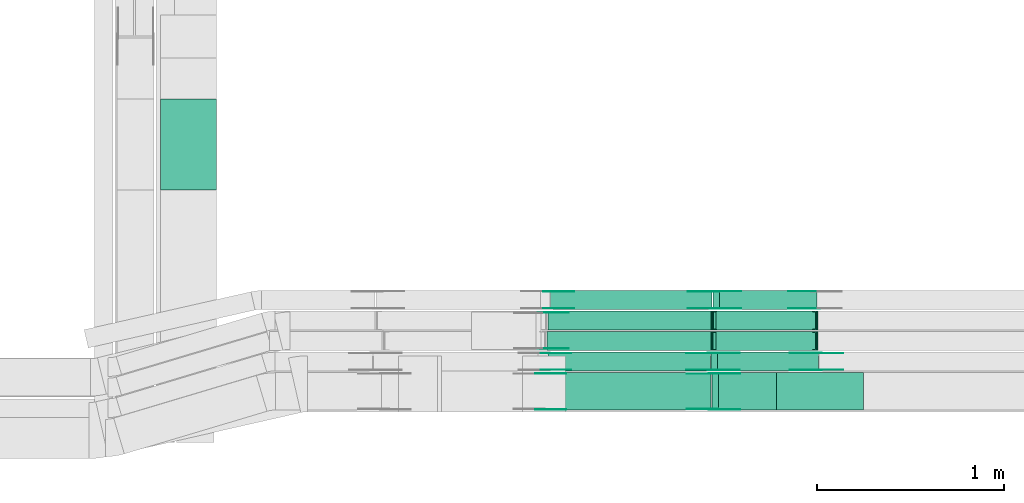
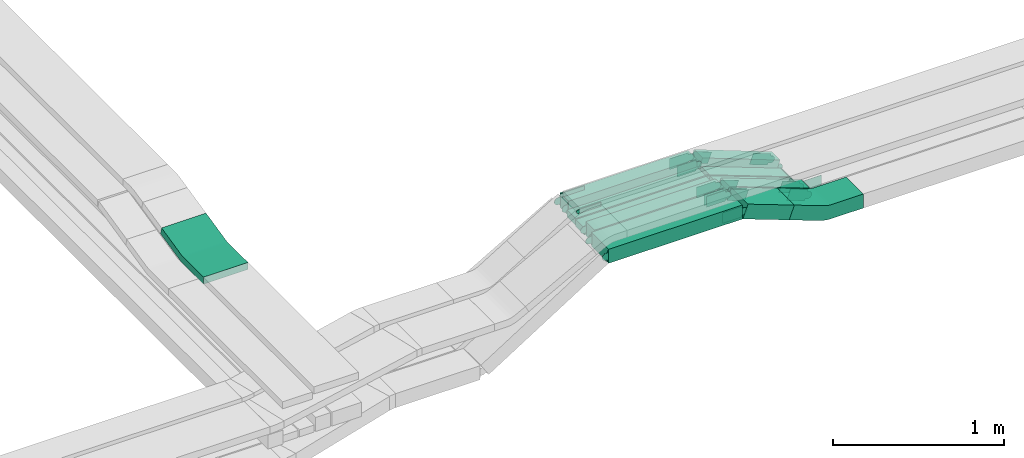
# One storey, part 26 of 31: 32 flow fittings, 10 flow segments.
"""IFC2X3 building model written with IfcOpenShell, lengths in millimetres."""

from ifc_helpers import new_model, entity, si_unit, converted_unit, derived_unit, direction, frame, frame_2d, origin, origin_2d_with_axis, place, context, subcontext, project, spatial, polyline, circle_curve, parameter, trimmed, segment, composite_curve, rectangle, outline, extrude, faceted_brep, source, transform, mapped, material, type_object, type_shapes, element, save


model = new_model("IFC2X3")

# Units and contexts
model_context = context("Model", 3, precision=0.01, world=origin(), true_north=direction((6.12303176911189e-17, 1.0)))
body_context = subcontext(model_context, "Body", "Model", "MODEL_VIEW")
ifc_project = project(units=[si_unit("LENGTHUNIT", "METRE", prefix="MILLI"), si_unit("AREAUNIT", "SQUARE_METRE"), si_unit("VOLUMEUNIT", "CUBIC_METRE"), converted_unit("PLANEANGLEUNIT", "DEGREE", entity("IfcRatioMeasure", 0.0174532925199433), si_unit("PLANEANGLEUNIT", "RADIAN"), dimensions=[0, 0, 0, 0, 0, 0, 0]), si_unit("MASSUNIT", "GRAM", prefix="KILO"), derived_unit("MASSDENSITYUNIT", [(si_unit("MASSUNIT", "GRAM", prefix="KILO"), 1), (si_unit("LENGTHUNIT", "METRE"), -3)]), derived_unit("MOMENTOFINERTIAUNIT", [(si_unit("LENGTHUNIT", "METRE"), 4)]), si_unit("TIMEUNIT", "SECOND"), si_unit("FREQUENCYUNIT", "HERTZ"), si_unit("THERMODYNAMICTEMPERATUREUNIT", "DEGREE_CELSIUS"), derived_unit("THERMALTRANSMITTANCEUNIT", [(si_unit("MASSUNIT", "GRAM", prefix="KILO"), 1), (si_unit("THERMODYNAMICTEMPERATUREUNIT", "KELVIN"), -1), (si_unit("TIMEUNIT", "SECOND"), -3)]), derived_unit("VOLUMETRICFLOWRATEUNIT", [(si_unit("LENGTHUNIT", "METRE"), 3), (si_unit("TIMEUNIT", "SECOND"), -1)]), derived_unit("MASSFLOWRATEUNIT", [(si_unit("MASSUNIT", "GRAM", prefix="KILO"), 1), (si_unit("TIMEUNIT", "SECOND"), -1)]), derived_unit("ROTATIONALFREQUENCYUNIT", [(si_unit("TIMEUNIT", "SECOND"), -1)]), si_unit("ELECTRICCURRENTUNIT", "AMPERE"), si_unit("ELECTRICVOLTAGEUNIT", "VOLT"), si_unit("POWERUNIT", "WATT"), si_unit("FORCEUNIT", "NEWTON", prefix="KILO"), si_unit("ILLUMINANCEUNIT", "LUX"), si_unit("LUMINOUSFLUXUNIT", "LUMEN"), si_unit("LUMINOUSINTENSITYUNIT", "CANDELA"), derived_unit("USERDEFINED", [(si_unit("MASSUNIT", "GRAM", prefix="KILO"), -1), (si_unit("LENGTHUNIT", "METRE"), -2), (si_unit("TIMEUNIT", "SECOND"), 3), (si_unit("LUMINOUSFLUXUNIT", "LUMEN"), 1)]), derived_unit("LINEARVELOCITYUNIT", [(si_unit("LENGTHUNIT", "METRE"), 1), (si_unit("TIMEUNIT", "SECOND"), -1)]), si_unit("PRESSUREUNIT", "PASCAL"), derived_unit("USERDEFINED", [(si_unit("LENGTHUNIT", "METRE"), -2), (si_unit("MASSUNIT", "GRAM", prefix="KILO"), 1), (si_unit("TIMEUNIT", "SECOND"), -2)]), derived_unit("LINEARFORCEUNIT", [(si_unit("MASSUNIT", "GRAM", prefix="KILO"), 1), (si_unit("LENGTHUNIT", "METRE"), 1), (si_unit("TIMEUNIT", "SECOND"), -2), (si_unit("LENGTHUNIT", "METRE"), -1)]), derived_unit("PLANARFORCEUNIT", [(si_unit("MASSUNIT", "GRAM", prefix="KILO"), 1), (si_unit("LENGTHUNIT", "METRE"), 1), (si_unit("TIMEUNIT", "SECOND"), -2), (si_unit("LENGTHUNIT", "METRE"), -2)])], contexts=[model_context])

# Site, building, storey
site_placement = place(None, frame((0.0, -0.00077364408347762, 0.0)))
site = spatial("IfcSite", under=ifc_project, at=site_placement, CompositionType="ELEMENT")
building_placement = place(site_placement, origin())
building = spatial("IfcBuilding", under=site, at=building_placement, CompositionType="ELEMENT")
storey_placement = place(building_placement, frame((0.0, 0.0, 15900.0)))
storey = spatial("IfcBuildingStorey", under=building, at=storey_placement, CompositionType="ELEMENT", Elevation=15900.0)

# Flow segments
cable_carrier_segment_type = type_object("IfcCableCarrierSegmentType", PredefinedType="CABLETRAYSEGMENT")
flow_segment_1_placement = place(storey_placement, frame((62529.74684317, 8474.9658623949, 3025.43501652419)))
element("IfcFlowSegment", 1, at=flow_segment_1_placement, inside=storey, type_object=cable_carrier_segment_type, context=body_context, shape_type="SweptSolid", body=[
    extrude(rectangle(XDim=901.526322667125, YDim=200.0, at=frame_2d((0.0, 1.08713038571295e-12), x_axis=(1.0, 0.0))), frame((450.763161333571, 100.0, 0.0)), (0.0, 0.0, 1.0), 99.9999999999989),
])
flow_segment_2_placement = place(storey_placement, frame((62557.0291841911, 8684.96586239497, 3025.43501652418)))
element("IfcFlowSegment", 2, at=flow_segment_2_placement, inside=storey, type_object=cable_carrier_segment_type, context=body_context, shape_type="SweptSolid", body=[
    extrude(rectangle(XDim=870.814775228981, YDim=100.000000000001, at=frame_2d((-8.66862137627322e-12, 0.0), x_axis=(1.0, 0.0))), frame((435.407387614499, 50.0, 0.0)), (0.0, 0.0, 1.0), 99.9999999999989),
])
flow_segment_3_placement = place(storey_placement, frame((62551.0270642643, 8794.96586239506, 3025.43501652417)))
element("IfcFlowSegment", 3, at=flow_segment_3_placement, inside=storey, type_object=cable_carrier_segment_type, context=body_context, shape_type="SweptSolid", body=[
    extrude(rectangle(XDim=879.269099914084, YDim=100.000000000001, at=frame_2d((4.32009983342141e-12, -1.08357767203415e-12), x_axis=(1.0, 0.0))), frame((439.634549957037, 50.0, 0.0)), (0.0, 0.0, 1.0), 50.0000000000016),
])
flow_segment_4_placement = place(storey_placement, frame((62556.9832529835, 8904.96586239505, 3025.43501652417)))
element("IfcFlowSegment", 4, at=flow_segment_4_placement, inside=storey, type_object=cable_carrier_segment_type, context=body_context, shape_type="SweptSolid", body=[
    extrude(rectangle(XDim=874.16186190821, YDim=100.000000000001, at=frame_2d((-4.32009983342141e-12, 0.0), x_axis=(1.0, 0.0))), frame((437.080930954109, 50.0, 0.0)), (0.0, 0.0, 1.0), 50.0000000000016),
])
flow_segment_5_placement = place(storey_placement, frame((62570.8651214086, 9014.96586239505, 3025.43501652418)))
element("IfcFlowSegment", 5, at=flow_segment_5_placement, inside=storey, type_object=cable_carrier_segment_type, context=body_context, shape_type="SweptSolid", body=[
    extrude(rectangle(XDim=865.233015267495, YDim=100.000000000001, at=frame_2d((-4.34852154285181e-12, 0.0), x_axis=(1.0, 0.0))), frame((432.616507633752, 50.0, 0.0)), (0.0, 0.0, 1.0), 99.9999999999989),
])
flow_segment_6_placement = place(storey_placement, frame((63434.6064292516, 8474.9658623949, 2908.57278616473)))
element("IfcFlowSegment", 6, at=flow_segment_6_placement, inside=storey, type_object=cable_carrier_segment_type, context=body_context, shape_type="SweptSolid", body=[
    extrude(rectangle(XDim=100.000000000008, YDim=200.0, at=frame_2d((-5.57776047571679e-12, 0.0), x_axis=(1.0, 0.0))), frame((17.4519391870551, 100.0, 163.11703866692), z_axis=(0.93710827946644, 0.0, -0.349038783741073), x_axis=(0.349038783741073, 0.0, 0.93710827946644)), (0.0, 0.0, 1.0), 333.090848665879),
])
flow_segment_7_placement = place(storey_placement, frame((63431.1704442719, 8684.96586239497, 2825.29581506794)))
element("IfcFlowSegment", 7, at=flow_segment_7_placement, inside=storey, type_object=cable_carrier_segment_type, context=body_context, shape_type="SweptSolid", body=[
    extrude(rectangle(XDim=99.9999999999998, YDim=99.9999999999989, at=origin_2d_with_axis()), frame((17.3585363463502, 50.0, 246.43333571092), z_axis=(0.937801944103858, 0.0, -0.347170726927005), x_axis=(0.347170726927005, 0.0, 0.937801944103858)), (0.0, 0.0, 1.0), 574.76976896054),
])
flow_segment_8_placement = place(storey_placement, frame((63439.0473194393, 8794.96586239505, 2823.22511407185)))
element("IfcFlowSegment", 8, at=flow_segment_8_placement, inside=storey, type_object=cable_carrier_segment_type, context=body_context, shape_type="SweptSolid", body=[
    extrude(rectangle(XDim=49.9999999999989, YDim=99.9999999999989, at=origin_2d_with_axis()), frame((8.75115526093145, 50.0, 224.046524089651), z_axis=(0.936732432746274, 0.0, -0.350046210436919), x_axis=(0.350046210436919, 0.0, 0.936732432746274)), (0.0, 0.0, 1.0), 573.147793888569),
])
flow_segment_9_placement = place(storey_placement, frame((63439.9074022185, 8904.96586239505, 2823.23760289713)))
element("IfcFlowSegment", 9, at=flow_segment_9_placement, inside=storey, type_object=cable_carrier_segment_type, context=body_context, shape_type="SweptSolid", body=[
    extrude(rectangle(XDim=50.0000000000006, YDim=100.000000000001, at=frame_2d((0.0, 1.08357767203415e-12), x_axis=(1.0, 0.0))), frame((8.76228732686138, 50.0, 224.02570938086), z_axis=(0.936565915076029, 0.0, -0.350491493074798), x_axis=(0.350491493074798, 0.0, 0.936565915076029)), (0.0, 0.0, 1.0), 572.372127334818),
])
flow_segment_10_placement = place(storey_placement, frame((63439.4556389315, 9014.96586239505, 2825.6384715158)))
element("IfcFlowSegment", 10, at=flow_segment_10_placement, inside=storey, type_object=cable_carrier_segment_type, context=body_context, shape_type="SweptSolid", body=[
    extrude(rectangle(XDim=99.9999999999993, YDim=100.000000000001, at=frame_2d((2.02504679691629e-12, -1.08357767203415e-12), x_axis=(1.0, 0.0))), frame((17.7864100183982, 50.0, 245.90864732213), z_axis=(0.934589453965198, 0.0, -0.355728200367967), x_axis=(0.355728200367967, 0.0, 0.934589453965198)), (0.0, 0.0, 1.0), 559.919552112584),
])

# Flow fittings
ifc_material_1 = material(Name="G")
cable_carrier_fitting_type_1 = type_object("IfcCableCarrierFittingType", PredefinedType="NOTDEFINED", material=ifc_material_1)
shared_shape_1 = source(origin(), body_context, "Body", "SweptSolid", [
    extrude(outline(composite_curve([segment(trimmed(circle_curve(frame_2d((-44.5901162790698, 0.0), x_axis=(1.0, 0.0)), 12.5), [parameter(90.0000000000007)], [parameter(270.0)], True, "PARAMETER"), True, "CONTINUOUS"), segment(polyline([(-44.5901162790697, -12.5), (-33.0901162790698, -12.5)]), True, "CONTINUOUS"), segment(polyline([(-33.0901162790698, -12.5), (-31.2296511627907, -14.5)]), True, "CONTINUOUS"), segment(polyline([(-31.2296511627907, -14.5), (108.90988372093, -14.5)]), True, "CONTINUOUS"), segment(polyline([(108.90988372093, -14.5), (108.90988372093, 14.5)]), True, "CONTINUOUS"), segment(polyline([(108.90988372093, 14.5), (-31.2296511627907, 14.5)]), True, "CONTINUOUS"), segment(polyline([(-31.2296511627907, 14.5), (-33.0901162790698, 12.5)]), True, "CONTINUOUS"), segment(polyline([(-33.0901162790698, 12.5), (-44.5901162790699, 12.5)]), True, "CONTINUOUS")], self_intersect=False)), frame((44.5901162790698, 0.0, 0.0), z_axis=(0.0, 0.0, -1.0), x_axis=(1.0, 0.0, 0.0)), (0.0, 0.0, -1.0), 2.0),
])
type_shapes(cable_carrier_fitting_type_1, [shared_shape_1])
flow_fitting_1_placement = place(storey_placement, frame((62513.820309519, 8995.60842320215, 3200.0), z_axis=(0.0, 1.0, 0.0), x_axis=(1.0, 0.0, 0.0)))
element("IfcFlowFitting", 11, at=flow_fitting_1_placement, inside=storey, type_object=cable_carrier_fitting_type_1, material=ifc_material_1, context=body_context, shape_type="MappedRepresentation", body=[
    mapped(shared_shape_1, transform((0.0, 0.0, 0.0), scale=1.0)),
])
cable_carrier_fitting_type_2 = type_object("IfcCableCarrierFittingType", PredefinedType="NOTDEFINED", material=ifc_material_1)
shared_shape_2 = source(origin(), body_context, "Body", "SweptSolid", [
    extrude(outline(composite_curve([segment(trimmed(circle_curve(frame_2d((-44.5901162790697, 0.0), x_axis=(1.0, 0.0)), 12.5), [parameter(90.0000000000007)], [parameter(270.0)], True, "PARAMETER"), True, "CONTINUOUS"), segment(polyline([(-44.5901162790697, -12.5), (-33.0901162790697, -12.5)]), True, "CONTINUOUS"), segment(polyline([(-33.0901162790697, -12.5), (-31.2296511627907, -14.5)]), True, "CONTINUOUS"), segment(polyline([(-31.2296511627907, -14.5), (108.90988372093, -14.5)]), True, "CONTINUOUS"), segment(polyline([(108.90988372093, -14.5), (108.90988372093, 14.5)]), True, "CONTINUOUS"), segment(polyline([(108.90988372093, 14.5), (-31.2296511627907, 14.5)]), True, "CONTINUOUS"), segment(polyline([(-31.2296511627907, 14.5), (-33.0901162790698, 12.5)]), True, "CONTINUOUS"), segment(polyline([(-33.0901162790698, 12.5), (-44.5901162790699, 12.5)]), True, "CONTINUOUS")], self_intersect=False)), frame((44.5901162790697, 0.0, 0.0)), (0.0, 0.0, 1.0), 2.0),
])
type_shapes(cable_carrier_fitting_type_2, [shared_shape_2])
flow_fitting_2_placement = place(storey_placement, frame((62513.820309519, 8804.68842318183, 3200.0), z_axis=(0.0, -1.0, 0.0), x_axis=(1.0, 0.0, 0.0)))
element("IfcFlowFitting", 12, at=flow_fitting_2_placement, inside=storey, type_object=cable_carrier_fitting_type_2, material=ifc_material_1, context=body_context, shape_type="MappedRepresentation", body=[
    mapped(shared_shape_2, transform((0.0, 0.0, 0.0), scale=1.0)),
])
cable_carrier_fitting_type_3 = type_object("IfcCableCarrierFittingType", PredefinedType="NOTDEFINED", material=ifc_material_1)
shared_shape_3 = source(origin(), body_context, "Body", "SweptSolid", [
    extrude(outline(composite_curve([segment(trimmed(circle_curve(frame_2d((-41.4651162790697, 0.0), x_axis=(1.0, 0.0)), 25.0), [parameter(90.0000000000007)], [parameter(270.0)], True, "PARAMETER"), True, "CONTINUOUS"), segment(polyline([(-41.4651162790697, -25.0), (-29.9651162790697, -25.0)]), True, "CONTINUOUS"), segment(polyline([(-29.9651162790697, -25.0), (-28.1046511627907, -38.5)]), True, "CONTINUOUS"), segment(polyline([(-28.1046511627907, -38.5), (99.5348837209303, -38.5)]), True, "CONTINUOUS"), segment(polyline([(99.5348837209303, -38.5), (99.5348837209303, 38.5)]), True, "CONTINUOUS"), segment(polyline([(99.5348837209303, 38.5), (-28.1046511627907, 38.5)]), True, "CONTINUOUS"), segment(polyline([(-28.1046511627907, 38.5), (-29.9651162790697, 25.0)]), True, "CONTINUOUS"), segment(polyline([(-29.9651162790697, 25.0), (-41.46511627907, 25.0)]), True, "CONTINUOUS")], self_intersect=False)), frame((41.4651162790697, 0.0, 0.0), z_axis=(0.0, 0.0, -1.0), x_axis=(1.0, 0.0, 0.0)), (0.0, 0.0, -1.0), 2.0),
])
type_shapes(cable_carrier_fitting_type_3, [shared_shape_3])
for number, where, z_axis, x_axis in (
    (13, (63438.5184358603, 8780.42586240513, 3075.4350165242), (0.0, 1.0, 0.0), (0.937801944103825, 0.0, -0.347170726927093)),
    (14, (63447.027541998, 9110.42586240521, 3075.4350165242), (0.0, 1.0, 0.0), (0.934589453965168, 0.0, -0.355728200368047)),
    (15, (63997.5597321195, 8780.42586240513, 2868.48004652779), (0.0, 1.0, 0.0), (-0.937801944103825, 0.0, 0.347170726927093)),
    (16, (63990.7514643752, 9110.42586240521, 2868.4800465278), (0.0, 1.0, 0.0), (-0.934589453965168, 0.0, 0.355728200368047)),
    (17, (62513.1082989591, 8670.42586240507, 3075.4350165242), (0.0, 1.0, 0.0), (1.0, 0.0, 0.0)),
    (18, (63442.0031817179, 8670.42586240506, 3075.43501652423), (0.0, 1.0, 0.0), (0.937108279466473, 0.0, -0.349038783740986)),
):
    element("IfcFlowFitting", number, at=place(storey_placement, frame(where, z_axis=z_axis, x_axis=x_axis)), inside=storey, type_object=cable_carrier_fitting_type_3, material=ifc_material_1, context=body_context, shape_type="MappedRepresentation", body=[
        mapped(shared_shape_3, transform((0.0, 0.0, 0.0), scale=1.0)),
    ])
cable_carrier_fitting_type_4 = type_object("IfcCableCarrierFittingType", PredefinedType="NOTDEFINED", material=ifc_material_1)
shared_shape_4 = source(origin(), body_context, "Body", "SweptSolid", [
    extrude(outline(composite_curve([segment(trimmed(circle_curve(frame_2d((-41.4651162790697, 0.0), x_axis=(1.0, 0.0)), 25.0), [parameter(90.0000000000007)], [parameter(270.0)], True, "PARAMETER"), True, "CONTINUOUS"), segment(polyline([(-41.4651162790697, -25.0), (-29.9651162790697, -25.0)]), True, "CONTINUOUS"), segment(polyline([(-29.9651162790697, -25.0), (-28.1046511627907, -38.5)]), True, "CONTINUOUS"), segment(polyline([(-28.1046511627907, -38.5), (99.5348837209303, -38.5)]), True, "CONTINUOUS"), segment(polyline([(99.5348837209303, -38.5), (99.5348837209303, 38.5)]), True, "CONTINUOUS"), segment(polyline([(99.5348837209303, 38.5), (-28.1046511627907, 38.5)]), True, "CONTINUOUS"), segment(polyline([(-28.1046511627907, 38.5), (-29.9651162790697, 25.0)]), True, "CONTINUOUS"), segment(polyline([(-29.9651162790697, 25.0), (-41.46511627907, 25.0)]), True, "CONTINUOUS")], self_intersect=False)), frame((41.4651162790697, 0.0, 0.0)), (0.0, 0.0, 1.0), 2.0),
])
type_shapes(cable_carrier_fitting_type_4, [shared_shape_4])
for number, where, z_axis, x_axis in (
    (19, (63438.5184358603, 8689.50586238481, 3075.4350165242), (0.0, -1.0, 0.0), (0.937801944103825, 0.0, -0.347170726927093)),
    (20, (63447.027541998, 9019.50586238489, 3075.4350165242), (0.0, -1.0, 0.0), (0.934589453965168, 0.0, -0.355728200368047)),
    (21, (63997.5597321195, 8689.50586238481, 2868.48004652779), (0.0, -1.0, 0.0), (-0.937801944103825, 0.0, 0.347170726927093)),
    (22, (63990.7514643752, 9019.50586238489, 2868.4800465278), (0.0, -1.0, 0.0), (-0.934589453965168, 0.0, 0.355728200368047)),
    (23, (62513.1082989591, 8479.50586238475, 3075.4350165242), (0.0, -1.0, 0.0), (1.0, 0.0, 0.0)),
    (24, (63442.0031817179, 8479.50586238474, 3075.43501652423), (0.0, -1.0, 0.0), (0.937108279466473, 0.0, -0.349038783740986)),
):
    element("IfcFlowFitting", number, at=place(storey_placement, frame(where, z_axis=z_axis, x_axis=x_axis)), inside=storey, type_object=cable_carrier_fitting_type_4, material=ifc_material_1, context=body_context, shape_type="MappedRepresentation", body=[
        mapped(shared_shape_4, transform((0.0, 0.0, 0.0), scale=1.0)),
    ])
cable_carrier_fitting_type_5 = type_object("IfcCableCarrierFittingType", PredefinedType="NOTDEFINED", material=ifc_material_1)
shared_shape_5 = source(origin(), body_context, "Body", "SweptSolid", [
    extrude(outline(composite_curve([segment(trimmed(circle_curve(frame_2d((-41.4651162790697, 0.0), x_axis=(1.0, 0.0)), 25.0), [parameter(90.0000000000007)], [parameter(270.0)], True, "PARAMETER"), True, "CONTINUOUS"), segment(polyline([(-41.4651162790697, -25.0), (-29.9651162790697, -25.0)]), True, "CONTINUOUS"), segment(polyline([(-29.9651162790697, -25.0), (-28.1046511627907, -38.5)]), True, "CONTINUOUS"), segment(polyline([(-28.1046511627907, -38.5), (99.5348837209303, -38.5)]), True, "CONTINUOUS"), segment(polyline([(99.5348837209303, -38.5), (99.5348837209303, 38.5)]), True, "CONTINUOUS"), segment(polyline([(99.5348837209303, 38.5), (-28.1046511627907, 38.5)]), True, "CONTINUOUS"), segment(polyline([(-28.1046511627907, 38.5), (-29.9651162790697, 25.0)]), True, "CONTINUOUS"), segment(polyline([(-29.9651162790697, 25.0), (-41.46511627907, 25.0)]), True, "CONTINUOUS")], self_intersect=False)), frame((41.4651162790697, 0.0, 0.0), z_axis=(0.0, 0.0, -1.0), x_axis=(1.0, 0.0, 0.0)), (0.0, 0.0, -1.0), 2.0),
])
type_shapes(cable_carrier_fitting_type_5, [shared_shape_5])
for number, where, z_axis, x_axis in (
    (25, (62541.5522892822, 8778.42586240514, 3075.43501652418), (0.0, 1.0, 0.0), (1.0, 0.0, 0.0)),
    (26, (62555.3882264997, 9108.42586240522, 3075.43501652419), (0.0, 1.0, 0.0), (1.0, 0.0, 0.0)),
    (27, (63438.5184358603, 8691.50586238481, 3075.43501652419), (0.0, -1.0, 0.0), (-1.0, 0.0, 0.0)),
    (28, (63447.027541998, 9021.50586238489, 3075.4350165242), (0.0, -1.0, 0.0), (-1.0, 0.0, 0.0)),
    (29, (63997.5597321195, 8691.50586238481, 2868.4800465278), (0.0, -1.0, 0.0), (1.0, 0.0, 0.0)),
    (30, (63442.0031817179, 8481.50586238474, 3075.43501652422), (0.0, -1.0, 0.0), (-1.0, 0.0, 0.0)),
):
    element("IfcFlowFitting", number, at=place(storey_placement, frame(where, z_axis=z_axis, x_axis=x_axis)), inside=storey, type_object=cable_carrier_fitting_type_5, material=ifc_material_1, context=body_context, shape_type="MappedRepresentation", body=[
        mapped(shared_shape_5, transform((0.0, 0.0, 0.0), scale=1.0)),
    ])
cable_carrier_fitting_type_6 = type_object("IfcCableCarrierFittingType", PredefinedType="NOTDEFINED", material=ifc_material_1)
shared_shape_6 = source(origin(), body_context, "Body", "SweptSolid", [
    extrude(outline(composite_curve([segment(trimmed(circle_curve(frame_2d((-41.4651162790697, 0.0), x_axis=(1.0, 0.0)), 25.0), [parameter(90.0000000000007)], [parameter(270.0)], True, "PARAMETER"), True, "CONTINUOUS"), segment(polyline([(-41.4651162790697, -25.0), (-29.9651162790697, -25.0)]), True, "CONTINUOUS"), segment(polyline([(-29.9651162790697, -25.0), (-28.1046511627907, -38.5)]), True, "CONTINUOUS"), segment(polyline([(-28.1046511627907, -38.5), (99.5348837209303, -38.5)]), True, "CONTINUOUS"), segment(polyline([(99.5348837209303, -38.5), (99.5348837209303, 38.5)]), True, "CONTINUOUS"), segment(polyline([(99.5348837209303, 38.5), (-28.1046511627907, 38.5)]), True, "CONTINUOUS"), segment(polyline([(-28.1046511627907, 38.5), (-29.9651162790697, 25.0)]), True, "CONTINUOUS"), segment(polyline([(-29.9651162790697, 25.0), (-41.46511627907, 25.0)]), True, "CONTINUOUS")], self_intersect=False)), frame((41.4651162790697, 0.0, 0.0)), (0.0, 0.0, 1.0), 2.0),
])
type_shapes(cable_carrier_fitting_type_6, [shared_shape_6])
for number, where, z_axis, x_axis in (
    (31, (62541.5522892822, 8691.50586238483, 3075.43501652418), (0.0, -1.0, 0.0), (1.0, 0.0, 0.0)),
    (32, (62555.3882264997, 9021.5058623849, 3075.43501652418), (0.0, -1.0, 0.0), (1.0, 0.0, 0.0)),
    (33, (63438.5184358603, 8778.42586240513, 3075.43501652419), (0.0, 1.0, 0.0), (-1.0, 0.0, 0.0)),
    (34, (63447.027541998, 9108.42586240521, 3075.4350165242), (0.0, 1.0, 0.0), (-1.0, 0.0, 0.0)),
    (35, (63997.5597321195, 8778.42586240513, 2868.4800465278), (0.0, 1.0, 0.0), (1.0, 0.0, 0.0)),
    (36, (63442.0031817179, 8668.42586240505, 3075.43501652422), (0.0, 1.0, 0.0), (-1.0, 0.0, 0.0)),
):
    element("IfcFlowFitting", number, at=place(storey_placement, frame(where, z_axis=z_axis, x_axis=x_axis)), inside=storey, type_object=cable_carrier_fitting_type_6, material=ifc_material_1, context=body_context, shape_type="MappedRepresentation", body=[
        mapped(shared_shape_6, transform((0.0, 0.0, 0.0), scale=1.0)),
    ])
ifc_material_2 = material()
cable_carrier_fitting_type_7 = type_object("IfcCableCarrierFittingType", Name="470_DKC_S5_CS 90 internal vertical angle:-", PredefinedType="NOTDEFINED", material=ifc_material_2)
shared_shape_7 = source(origin(), body_context, "Body", "SweptSolid", [
    extrude(outline(composite_curve([segment(polyline([(-248.688096365734, -39.6931080473409), (-14.0168484735831, -39.6931080473409)]), True, "CONTINUOUS"), segment(trimmed(circle_curve(frame_2d((-14.0168484735834, 125.306891952658), x_axis=(0.0, -1.0)), 164.999999999999), [parameter(0.0)], [parameter(12.7651639618241)], True, "PARAMETER"), True, "CONTINUOUS"), segment(polyline([(22.4408193261965, -35.6149476422227), (251.311903634266, 16.2369699202732)]), True, "CONTINUOUS"), segment(polyline([(251.311903634266, 16.2369699202732), (240.26412551312, 65.0011637369044)]), True, "CONTINUOUS"), segment(polyline([(240.26412551312, 65.0011637369044), (11.3930412050509, 13.1492461744084)]), True, "CONTINUOUS"), segment(trimmed(circle_curve(frame_2d((-14.0168484735834, 125.306891952658), x_axis=(0.0, -1.0)), 114.999999999999), [parameter(0.0)], [parameter(12.7651639618241)], True, "PARAMETER"), False, "CONTINUOUS"), segment(polyline([(-14.0168484735831, 10.3068919526594), (-248.688096365734, 10.3068919526594)]), True, "CONTINUOUS"), segment(polyline([(-248.688096365734, 10.3068919526594), (-248.688096365734, -39.6931080473408)]), True, "CONTINUOUS")], self_intersect=False)), frame((-1.64357335733978, 14.6931080473336, -150.0)), (0.0, 0.0, 1.0), 300.0),
])
type_shapes(cable_carrier_fitting_type_7, [shared_shape_7])
flow_fitting_3_placement = place(storey_placement, frame((60630.8175590596, 9903.61601629266, 2905.0), z_axis=(1.0, 0.0, 0.0), x_axis=(0.0, 1.0, 0.0)))
element("IfcFlowFitting", 37, at=flow_fitting_3_placement, inside=storey, type_object=cable_carrier_fitting_type_7, material=ifc_material_2, Name="470_DKC_S5_CS 90 internal vertical angle:-", ObjectType="470_DKC_S5_CS 90 internal vertical angle:-", context=body_context, shape_type="MappedRepresentation", body=[
    mapped(shared_shape_7, transform((0.0, 0.0, 0.0), scale=1.0)),
])
cable_carrier_fitting_type_8 = type_object("IfcCableCarrierFittingType", Name="470_DKC_S5_CS 90 internal vertical angle:-", PredefinedType="NOTDEFINED", material=ifc_material_2)
shared_shape_8 = source(origin(), body_context, "Body", "SweptSolid", [
    extrude(outline(composite_curve([segment(polyline([(-244.723276878259, -74.331321874562), (-25.3464531868425, -74.331321874562)]), True, "CONTINUOUS"), segment(trimmed(circle_curve(frame_2d((-25.3464531868428, 140.668678125437), x_axis=(0.0, -1.0)), 214.999999999999), [parameter(0.0)], [parameter(20.4285341071695)], True, "PARAMETER"), True, "CONTINUOUS"), segment(polyline([(49.6968853174508, -60.8096019598604), (255.276723121741, 15.7614177623335)]), True, "CONTINUOUS"), segment(polyline([(255.276723121741, 15.7614177623335), (220.372844747651, 109.472245708984)]), True, "CONTINUOUS"), segment(polyline([(220.372844747651, 109.472245708984), (14.7930069433605, 32.9012259867902)]), True, "CONTINUOUS"), segment(trimmed(circle_curve(frame_2d((-25.3464531868428, 140.668678125437), x_axis=(0.0, -1.0)), 114.999999999999), [parameter(0.0)], [parameter(20.4285341071695)], True, "PARAMETER"), False, "CONTINUOUS"), segment(polyline([(-25.3464531868425, 25.6686781254383), (-244.723276878259, 25.6686781254383)]), True, "CONTINUOUS"), segment(polyline([(-244.723276878259, 25.6686781254383), (-244.723276878259, -74.331321874562)]), True, "CONTINUOUS")], self_intersect=False)), frame((-4.38415089332394, 24.3313218745547, -100.0)), (0.0, 0.0, 1.0), 200.0),
])
type_shapes(cable_carrier_fitting_type_8, [shared_shape_8])
flow_fitting_4_placement = place(storey_placement, frame((63997.6411935793, 8574.9658623949, 2868.48004652785), z_axis=(0.0, 1.0, 0.0), x_axis=(-1.0, 0.0, 0.0)))
element("IfcFlowFitting", 38, at=flow_fitting_4_placement, inside=storey, type_object=cable_carrier_fitting_type_8, material=ifc_material_2, Name="470_DKC_S5_CS 90 internal vertical angle:-", ObjectType="470_DKC_S5_CS 90 internal vertical angle:-", context=body_context, shape_type="MappedRepresentation", body=[
    mapped(shared_shape_8, transform((0.0, 0.0, 0.0), scale=1.0)),
])
cable_carrier_fitting_type_9 = type_object("IfcCableCarrierFittingType", PredefinedType="NOTDEFINED", material=ifc_material_2)
shared_shape_9 = source(origin(), body_context, "Body", "Brep", [
    faceted_brep([(-9.03703073585146, 25.0, 50.0), (-9.03703073585146, 25.0, -50.0), (-9.03703073585162, -25.0, -50.0), (-9.03703073585162, -25.0, -47.4600000101565), (-9.03703073585146, 22.46000001016, -47.4600000101565), (-9.03703073585146, 22.46000001016, 47.4600000101635), (-9.03703073585162, -25.0, 47.4600000101635), (-9.03703073585162, -25.0, 50.0), (-0.285875474926759, 26.5816891813433, 50.0), (17.2164350469225, -20.2549324559691, 50.0), (17.2164350469225, -20.2549324559691, 47.4600000101635), (0.603241896026717, 24.2023888116851, 47.4600000101635), (0.603241896026707, 24.2023888116851, -47.4600000101565), (17.2164350469225, -20.2549324559691, -47.4600000101565), (17.2164350469225, -20.2549324559691, -50.0), (-0.285875474926757, 26.5816891813433, -50.0), (-4.51851536792542, 25.0, 50.0), (-4.51851536792551, 25.0, -50.0), (4.51851536792642, -25.0, -50.0), (4.51851536792642, -25.0, -47.4600000101565), (-4.05943420838056, 22.46000001016, -47.4600000101565), (-4.05943420838056, 22.46000001016, 47.4600000101635), (4.51851536792642, -25.0, 47.4600000101635), (4.51851536792642, -25.0, 50.0)], [[[0, 1, 2, 3, 4, 5, 6, 7]], [[8, 9, 10, 11, 12, 13, 14, 15]], [[1, 0, 16, 17]], [[2, 1, 17, 15, 14, 18]], [[3, 2, 18, 19]], [[4, 3, 19, 13, 12, 20]], [[5, 4, 20, 21]], [[6, 5, 21, 11, 10, 22]], [[7, 6, 22, 23]], [[0, 7, 23, 9, 8, 16]], [[17, 16, 8, 15]], [[19, 18, 14, 13]], [[21, 20, 12, 11]], [[23, 22, 10, 9]]]),
])
type_shapes(cable_carrier_fitting_type_9, [shared_shape_9])
for number, where, z_axis, x_axis in (
    (39, (63439.3331949142, 8844.96586239506, 3050.43501652418), (0.0, 1.0, 0.0), (1.0, 0.0, 0.0)),
    (40, (63993.1498817786, 8844.96586239505, 2843.48004652783), (0.0, -1.0, 0.0), (0.936732432746256, 0.0, -0.350046210436966)),
):
    element("IfcFlowFitting", number, at=place(storey_placement, frame(where, z_axis=z_axis, x_axis=x_axis)), inside=storey, type_object=cable_carrier_fitting_type_9, material=ifc_material_2, context=body_context, shape_type="MappedRepresentation", body=[
        mapped(shared_shape_9, transform((0.0, 0.0, 0.0), scale=1.0)),
    ])
cable_carrier_fitting_type_10 = type_object("IfcCableCarrierFittingType", PredefinedType="NOTDEFINED", material=ifc_material_2)
shared_shape_10 = source(origin(), body_context, "Body", "Brep", [
    faceted_brep([(-9.04930450201112, 25.0, 50.0), (-9.04930450201112, 25.0, -50.0), (-9.04930450201128, -25.0, -50.0), (-9.04930450201128, -25.0, -47.4600000101565), (-9.04930450201113, 22.46000001016, -47.4600000101565), (-9.04930450201113, 22.46000001016, 47.4600000101635), (-9.04930450201128, -25.0, 47.4600000101635), (-9.04930450201128, -25.0, 50.0), (-0.287017175141121, 26.5858521230988, 50.0), (17.2375574785987, -20.2424436307026, 50.0), (17.2375574785987, -20.2424436307026, 47.4600000101635), (0.603231213707874, 24.2069747083212, 47.4600000101635), (0.603231213707859, 24.2069747083213, -47.4600000101565), (17.2375574785987, -20.2424436307026, -47.4600000101565), (17.2375574785987, -20.2424436307026, -50.0), (-0.287017175141119, 26.5858521230988, -50.0), (-4.52465225100525, 25.0, 50.0), (-4.52465225100534, 25.0, -50.0), (4.52465225100625, -25.0, -50.0), (4.52465225100625, -25.0, -47.4600000101565), (-4.06494758414197, 22.46000001016, -47.4600000101565), (-4.06494758414197, 22.46000001016, 47.4600000101635), (4.52465225100625, -25.0, 47.4600000101635), (4.52465225100625, -25.0, 50.0)], [[[0, 1, 2, 3, 4, 5, 6, 7]], [[8, 9, 10, 11, 12, 13, 14, 15]], [[1, 0, 16, 17]], [[2, 1, 17, 15, 14, 18]], [[3, 2, 18, 19]], [[4, 3, 19, 13, 12, 20]], [[5, 4, 20, 21]], [[6, 5, 21, 11, 10, 22]], [[7, 6, 22, 23]], [[0, 7, 23, 9, 8, 16]], [[17, 16, 8, 15]], [[19, 18, 14, 13]], [[21, 20, 12, 11]], [[23, 22, 10, 9]]]),
])
type_shapes(cable_carrier_fitting_type_10, [shared_shape_10])
for number, where, z_axis, x_axis in (
    (41, (63993.2091848985, 8954.96586239505, 2843.48004652784), (0.0, 1.0, 0.0), (-1.0, 0.0, 0.0)),
    (42, (63440.1944193937, 8954.96586239505, 3050.43501652418), (0.0, 1.0, 0.0), (1.0, 0.0, 0.0)),
):
    element("IfcFlowFitting", number, at=place(storey_placement, frame(where, z_axis=z_axis, x_axis=x_axis)), inside=storey, type_object=cable_carrier_fitting_type_10, material=ifc_material_2, context=body_context, shape_type="MappedRepresentation", body=[
        mapped(shared_shape_10, transform((0.0, 0.0, 0.0), scale=1.0)),
    ])

save(model, "model.ifc")
